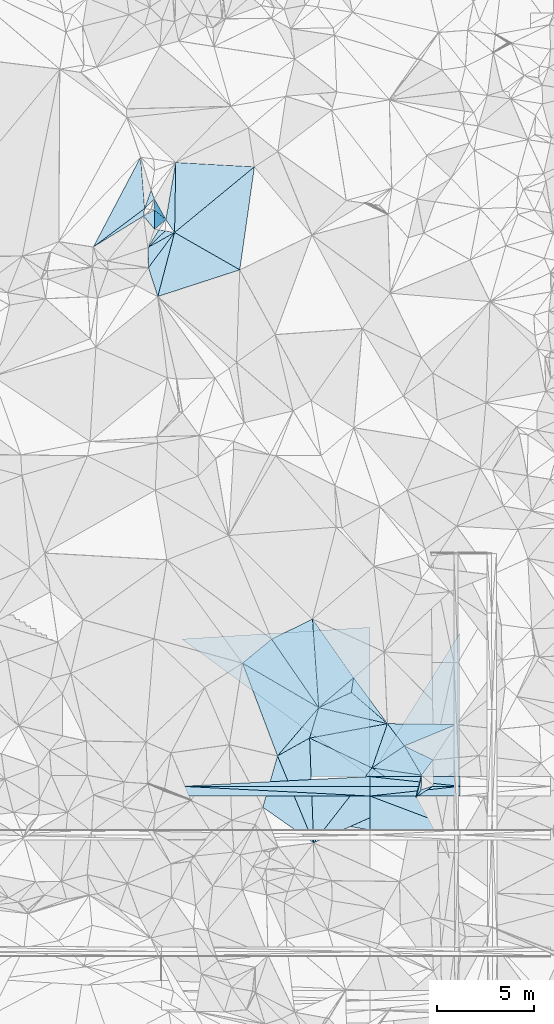
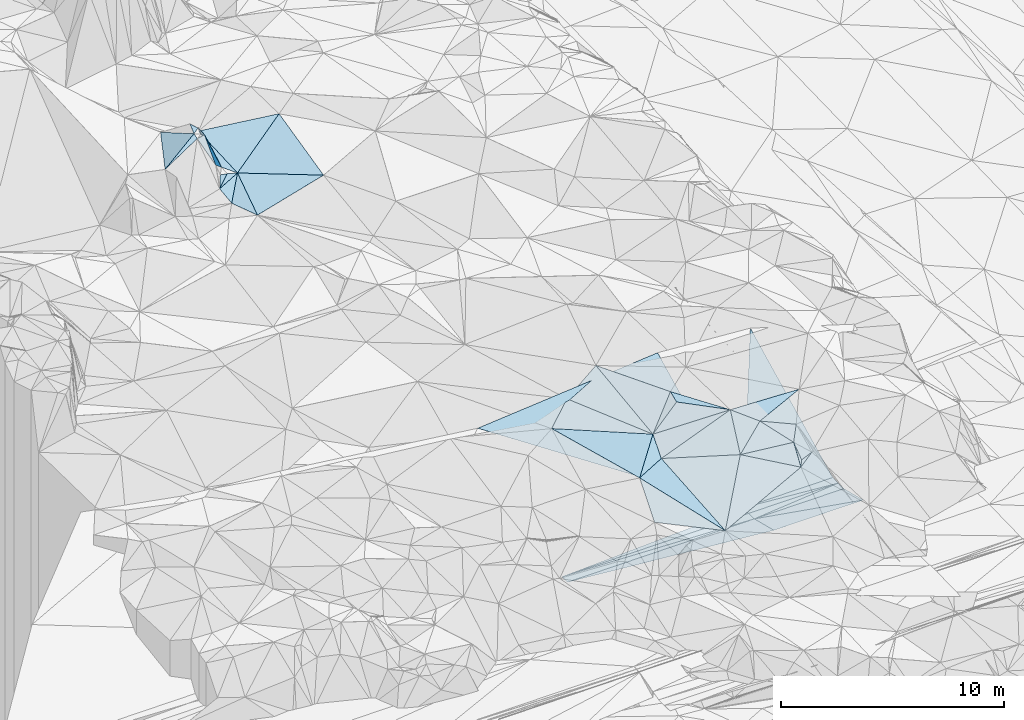
# One storey, part 77 of 275: 47 plates.
"""IFC2X3 building model written with IfcOpenShell, lengths in millimetres."""

from ifc_helpers import new_model, si_unit, frame, origin_with_axes, place, context, subcontext, project, spatial, polyline, outline, extrude, material, type_object, element, save


model = new_model("IFC2X3")

# Units and contexts
model_context = context("Model", 3, precision=1e-05, world=origin_with_axes())
body_context = subcontext(model_context, "Body", "Model", "MODEL_VIEW")
ifc_project = project(units=[si_unit("LENGTHUNIT", "METRE", prefix="MILLI"), si_unit("AREAUNIT", "SQUARE_METRE"), si_unit("VOLUMEUNIT", "CUBIC_METRE"), si_unit("MASSUNIT", "GRAM", prefix="KILO"), si_unit("TIMEUNIT", "SECOND"), si_unit("PLANEANGLEUNIT", "RADIAN"), si_unit("SOLIDANGLEUNIT", "STERADIAN"), si_unit("THERMODYNAMICTEMPERATUREUNIT", "DEGREE_CELSIUS"), si_unit("LUMINOUSINTENSITYUNIT", "LUMEN")], contexts=[model_context])

# Site, building, storey
site_placement = place(None, origin_with_axes())
site = spatial("IfcSite", under=ifc_project, at=site_placement, CompositionType="ELEMENT")
building_placement = place(site_placement, origin_with_axes())
building = spatial("IfcBuilding", under=site, at=building_placement, Name="Undefined", CompositionType="ELEMENT")
storey_placement = place(building_placement, origin_with_axes())
storey = spatial("IfcBuildingStorey", under=building, at=storey_placement, Name="Undefined", CompositionType="ELEMENT", Elevation=0.0)

# Plates
ifc_material = material()
plate_type_1 = type_object("IfcPlateType", PredefinedType="NOTDEFINED")
plate_1_placement = place(storey_placement, frame((-121491.980656783, 95456.9355654821, 53399.5115140249), z_axis=(-0.145244043643726, 0.156607274942495, -0.976922888062873), x_axis=(-0.021187068258557, 0.986674614416757, 0.161320530014474)))
element("IfcPlate", 1, at=plate_1_placement, inside=storey, type_object=plate_type_1, material=ifc_material, Name="00", context=body_context, shape_type="SweptSolid", body=[
    extrude(outline(polyline([(0.0, 0.0), (1053.80261230469, 3.75439412891865e-09), (1769.68615722656, 1396.42785644531), (0.0, 0.0)])), frame((-8.85201319254618e-08, 2.18876761149539e-07, -0.5000001331573), z_axis=(0.0, 0.0, 1.0), x_axis=(1.0, 0.0, 0.0)), (0.0, 0.0, 1.0), 1.0),
])
plate_type_2 = type_object("IfcPlateType", PredefinedType="NOTDEFINED")
plate_2_placement = place(storey_placement, frame((-121514.303984723, 96496.6892032592, 53569.5099623976), z_axis=(-0.137919534677873, 0.143254169517265, -0.980028797980017), x_axis=(0.720392885635616, 0.69356621192615, 1.2509960280384e-10)))
element("IfcPlate", 2, at=plate_2_placement, inside=storey, type_object=plate_type_2, material=ifc_material, Name="00", context=body_context, shape_type="SweptSolid", body=[
    extrude(outline(polyline([(0.0, 0.0), (1224.29577636719, -4.80213202536106e-09), (1516.79040527344, 402.301940917969), (0.0, 0.0)])), frame((-8.85201319254618e-08, 2.18876761149539e-07, -0.5000001331573), z_axis=(0.0, 0.0, 1.0), x_axis=(1.0, 0.0, 0.0)), (0.0, 0.0, 1.0), 1.0),
])
plate_type_3 = type_object("IfcPlateType", PredefinedType="NOTDEFINED")
plate_3_placement = place(storey_placement, frame((-116658.167121345, 75125.2155473122, 51699.5018499605), z_axis=(-0.0256559116857548, 0.0822326815628769, -0.99628287161757), x_axis=(0.861731287211786, -0.503345605832121, -0.063736878883529)))
element("IfcPlate", 3, at=plate_3_placement, inside=storey, type_object=plate_type_3, material=ifc_material, Name="00", context=body_context, shape_type="SweptSolid", body=[
    extrude(outline(polyline([(0.0, 0.0), (4549.9560546875, -7.78527464717627e-10), (3981.13745117188, 3214.13208007813), (0.0, 0.0)])), frame((-8.85201319254618e-08, 2.18876761149539e-07, -0.5000001331573), z_axis=(0.0, 0.0, 1.0), x_axis=(1.0, 0.0, 0.0)), (0.0, 0.0, 1.0), 1.0),
])
plate_type_4 = type_object("IfcPlateType", PredefinedType="NOTDEFINED")
plate_4_placement = place(storey_placement, frame((-108335.575539405, 70866.889105489, 51779.5331533235), z_axis=(0.0161646177763644, 0.357748358320823, -0.933678112226532), x_axis=(0.88752902296513, -0.435175224685755, -0.151376210859778)))
element("IfcPlate", 4, at=plate_4_placement, inside=storey, type_object=plate_type_4, material=ifc_material, Name="00", context=body_context, shape_type="SweptSolid", body=[
    extrude(outline(polyline([(0.0, 0.0), (1651.51440429688, -3.0740920919925e-09), (1521.33093261719, 1015.89971923828), (0.0, 0.0)])), frame((-8.85201319254618e-08, 2.18876761149539e-07, -0.5000001331573), z_axis=(0.0, 0.0, 1.0), x_axis=(1.0, 0.0, 0.0)), (0.0, 0.0, 1.0), 1.0),
])
plate_type_5 = type_object("IfcPlateType", PredefinedType="NOTDEFINED")
for number, where, z_axis, x_axis, name in (
    (5, (-105468.884921601, 68792.9344781819, 48637.3170075506), (0.00703682011736074, -4.02993598015843e-07, -0.99997524127474), (-0.994210620471608, 0.107220772025052, -0.00699629815053093), "00_PR"),
    (6, (-110107.626458422, 69293.20015366, 48604.6740069205), (0.00703682011736074, -4.02993598015843e-07, -0.99997524127474), (0.994210620472886, -0.107220772013634, 0.00699629814400315), "00_PR"),
):
    element("IfcPlate", number, at=place(storey_placement, frame(where, z_axis=z_axis, x_axis=x_axis)), inside=storey, type_object=plate_type_5, material=ifc_material, Name=name, context=body_context, shape_type="SweptSolid", body=[
        extrude(outline(polyline([(0.0, 0.0), (4665.75341796875, -5.16592990607023e-09), (53.5819053649902, 497.120697021484), (0.0, 0.0)])), frame((-8.85201319254618e-08, 2.18876761149539e-07, -0.5000001331573), z_axis=(0.0, 0.0, 1.0), x_axis=(1.0, 0.0, 0.0)), (0.0, 0.0, 1.0), 1.0),
    ])
plate_5_placement = place(storey_placement, frame((-110107.625814173, 69293.2001541532, 48604.674012009), z_axis=(0.00832550512650313, -4.76525014343269e-07, -0.999965342381505), x_axis=(-5.72939716861899e-05, -0.9999999983587, -3.69036567042244e-11)))
element("IfcPlate", 7, at=plate_5_placement, inside=storey, type_object=plate_type_5, material=ifc_material, Name="00_PR", context=body_context, shape_type="SweptSolid", body=[
    extrude(outline(polyline([(0.0, 0.0), (500.0, 8.00355337560177e-10), (499.999786376953, 9668.689453125), (0.0, 0.0)])), frame((-8.85201319254618e-08, 2.18876761149539e-07, -0.5000001331573), z_axis=(0.0, 0.0, 1.0), x_axis=(1.0, 0.0, 0.0)), (0.0, 0.0, 1.0), 1.0),
])
for number, where, z_axis, x_axis, name in (
    (8, (-105468.884921601, 68792.9344781819, 48637.3170075506), (0.00703682011736074, -4.02993598015843e-07, -0.99997524127474), (-5.72939716861899e-05, -0.9999999983587, -3.69036567042244e-11), "00_PR"),
    (9, (-110107.683753915, 68293.2001459784, 48604.6740072747), (0.00703682011736074, -4.02993598015843e-07, -0.99997524127474), (5.72939566107594e-05, 0.999999998358701, 3.92465150362411e-11), "00_PR"),
):
    element("IfcPlate", number, at=place(storey_placement, frame(where, z_axis=z_axis, x_axis=x_axis)), inside=storey, type_object=plate_type_5, material=ifc_material, Name=name, context=body_context, shape_type="SweptSolid", body=[
        extrude(outline(polyline([(0.0, 0.0), (500.0, 8.00355337560177e-10), (500.000091552734, 4638.88525390625), (0.0, 0.0)])), frame((-8.85201319254618e-08, 2.18876761149539e-07, -0.5000001331573), z_axis=(0.0, 0.0, 1.0), x_axis=(1.0, 0.0, 0.0)), (0.0, 0.0, 1.0), 1.0),
    ])
for number, where, z_axis, x_axis, name in (
    (10, (-119776.008774443, 68793.7543278347, 48524.17701052), (0.00832550512650313, -4.76525014343269e-07, -0.999965342381505), (0.998627967402267, -0.0517015939711349, 0.00831431914595258), "00_PR"),
    (11, (-110107.683106759, 68293.200145298, 48604.6740122975), (0.00832550512650313, -4.76525014343269e-07, -0.999965342381505), (-0.998627967401277, 0.0517015939893386, -0.00831431915169653), "00_PR"),
):
    element("IfcPlate", number, at=place(storey_placement, frame(where, z_axis=z_axis, x_axis=x_axis)), inside=storey, type_object=plate_type_5, material=ifc_material, Name=name, context=body_context, shape_type="SweptSolid", body=[
        extrude(outline(polyline([(0.0, 0.0), (9681.609375, -1.20489858090878e-08), (25.8221664428711, 499.332763671875), (0.0, 0.0)])), frame((-8.85201319254618e-08, 2.18876761149539e-07, -0.5000001331573), z_axis=(0.0, 0.0, 1.0), x_axis=(1.0, 0.0, 0.0)), (0.0, 0.0, 1.0), 1.0),
    ])
plate_type_6 = type_object("IfcPlateType", PredefinedType="NOTDEFINED")
plate_6_placement = place(storey_placement, frame((-113058.252267618, 77394.6399255898, 52519.5254217645), z_axis=(0.197861321106746, 0.244990522690057, -0.949120930862841), x_axis=(0.570396779252502, -0.816225689000043, -0.0917776597804555)))
element("IfcPlate", 12, at=plate_6_placement, inside=storey, type_object=plate_type_6, material=ifc_material, Name="00", context=body_context, shape_type="SweptSolid", body=[
    extrude(outline(polyline([(0.0, 0.0), (3704.60522460938, -2.03726813197136e-08), (4006.60766601563, 2464.08081054688), (0.0, 0.0)])), frame((-8.85201319254618e-08, 2.18876761149539e-07, -0.5000001331573), z_axis=(0.0, 0.0, 1.0), x_axis=(1.0, 0.0, 0.0)), (0.0, 0.0, 1.0), 1.0),
])
plate_type_7 = type_object("IfcPlateType", PredefinedType="NOTDEFINED")
plate_7_placement = place(storey_placement, frame((-107453.118329928, 69365.4981168583, 51219.5382379114), z_axis=(0.0589039544589741, 0.379068719327765, -0.923491867953532), x_axis=(-0.989526104038658, 0.144301784820489, -0.00388385423208294)))
element("IfcPlate", 13, at=plate_7_placement, inside=storey, type_object=plate_type_7, material=ifc_material, Name="00", context=body_context, shape_type="SweptSolid", body=[
    extrude(outline(polyline([(0.0, 0.0), (2574.76220703125, 2.43016984313726e-09), (1087.67333984375, 1470.87280273438), (0.0, 0.0)])), frame((-8.85201319254618e-08, 2.18876761149539e-07, -0.5000001331573), z_axis=(0.0, 0.0, 1.0), x_axis=(1.0, 0.0, 0.0)), (0.0, 0.0, 1.0), 1.0),
])
plate_type_8 = type_object("IfcPlateType", PredefinedType="NOTDEFINED")
plate_8_placement = place(storey_placement, frame((-114856.193535018, 70356.6749841936, 51259.507951789), z_axis=(-0.116281114862907, 0.134398896140523, -0.984081114056381), x_axis=(0.873875615125201, 0.484735152316241, -0.0370572718707482)))
element("IfcPlate", 14, at=plate_8_placement, inside=storey, type_object=plate_type_8, material=ifc_material, Name="00", context=body_context, shape_type="SweptSolid", body=[
    extrude(outline(polyline([(0.0, 0.0), (1888.96801757813, 6.54836185276508e-10), (-514.302001953125, 4884.88427734375), (0.0, 0.0)])), frame((-8.85201319254618e-08, 2.18876761149539e-07, -0.5000001331573), z_axis=(0.0, 0.0, 1.0), x_axis=(1.0, 0.0, 0.0)), (0.0, 0.0, 1.0), 1.0),
])
plate_type_9 = type_object("IfcPlateType", PredefinedType="NOTDEFINED")
plate_9_placement = place(storey_placement, frame((-112737.268732479, 72835.0948948373, 51409.5169961411), z_axis=(0.0922023741555557, 0.241653469669306, -0.965972216369014), x_axis=(-0.560003411586896, 0.814730872466991, 0.150365502892828)))
element("IfcPlate", 15, at=plate_9_placement, inside=storey, type_object=plate_type_9, material=ifc_material, Name="00", context=body_context, shape_type="SweptSolid", body=[
    extrude(outline(polyline([(0.0, 0.0), (4322.7998046875, 3.24580469168723e-08), (4061.48779296875, 2372.53369140625), (0.0, 0.0)])), frame((-8.85201319254618e-08, 2.18876761149539e-07, -0.5000001331573), z_axis=(0.0, 0.0, 1.0), x_axis=(1.0, 0.0, 0.0)), (0.0, 0.0, 1.0), 1.0),
])
plate_type_10 = type_object("IfcPlateType", PredefinedType="NOTDEFINED")
plate_10_placement = place(storey_placement, frame((-121011.464245367, 93974.5100086701, 53479.502445469), z_axis=(0.0967190391103134, -0.0223575900648491, -0.995060583904352), x_axis=(-0.307888860082838, 0.950039774583614, -0.0512725710883228)))
element("IfcPlate", 16, at=plate_10_placement, inside=storey, type_object=plate_type_10, material=ifc_material, Name="00", context=body_context, shape_type="SweptSolid", body=[
    extrude(outline(polyline([(0.0, 0.0), (1560.28845214844, 9.24046617001295e-09), (2859.34301757813, 1842.35095214844), (0.0, 0.0)])), frame((-8.85201319254618e-08, 2.18876761149539e-07, -0.5000001331573), z_axis=(0.0, 0.0, 1.0), x_axis=(1.0, 0.0, 0.0)), (0.0, 0.0, 1.0), 1.0),
])
plate_type_11 = type_object("IfcPlateType", PredefinedType="NOTDEFINED")
plate_11_placement = place(storey_placement, frame((-121688.040251305, 98497.2145120116, 55429.5025942348), z_axis=(-0.0940857772697721, 0.0399869239065555, -0.994760731247487), x_axis=(-0.149852085832661, -0.988378057479931, -0.0255571489763316)))
element("IfcPlate", 17, at=plate_11_placement, inside=storey, type_object=plate_type_11, material=ifc_material, Name="00", context=body_context, shape_type="SweptSolid", body=[
    extrude(outline(polyline([(0.0, 0.0), (391.279937744141, -1.80443748831749e-09), (2342.568359375, 2322.27783203125), (0.0, 0.0)])), frame((-8.85201319254618e-08, 2.18876761149539e-07, -0.5000001331573), z_axis=(0.0, 0.0, 1.0), x_axis=(1.0, 0.0, 0.0)), (0.0, 0.0, 1.0), 1.0),
])
plate_type_12 = type_object("IfcPlateType", PredefinedType="NOTDEFINED")
for number, where, z_axis, x_axis, name in (
    (18, (-105469.013941347, 66542.8131981337, 49074.831934969), (0.00681283794778126, -0.242530362302773, -0.970119893930839), (-0.999975239635043, 5.72709690146696e-05, -0.00703682008264182), "00_PR"),
    (19, (-110107.683861125, 68293.0788822064, 48604.688934529), (0.00681283794778126, -0.242530362302773, -0.970119893930839), (0.99997523963564, -5.72709999785377e-05, 0.00703681999743575), "00_PR"),
):
    element("IfcPlate", number, at=place(storey_placement, frame(where, z_axis=z_axis, x_axis=x_axis)), inside=storey, type_object=plate_type_12, material=ifc_material, Name=name, context=body_context, shape_type="SweptSolid", body=[
        extrude(outline(polyline([(0.0, 0.0), (4638.88525390625, 2.71393219009042e-09), (4641.96337890625, 1803.85607910156), (0.0, 0.0)])), frame((-8.85201319254618e-08, 2.18876761149539e-07, -0.5000001331573), z_axis=(0.0, 0.0, 1.0), x_axis=(1.0, 0.0, 0.0)), (0.0, 0.0, 1.0), 1.0),
    ])
plate_type_13 = type_object("IfcPlateType", PredefinedType="NOTDEFINED")
plate_12_placement = place(storey_placement, frame((-119776.037549467, 68293.6330597167, 48524.1919376552), z_axis=(0.00806306952558709, -0.242528174049018, -0.970110855367713), x_axis=(0.999965340787191, -5.73519775278889e-05, 0.0083254990906575)))
element("IfcPlate", 20, at=plate_12_placement, inside=storey, type_object=plate_type_13, material=ifc_material, Name="00_PR", context=body_context, shape_type="SweptSolid", body=[
    extrude(outline(polyline([(0.0, 0.0), (9668.689453125, -4.80504240840673e-08), (9672.33203125, 1803.85510253906), (0.0, 0.0)])), frame((-8.85201319254618e-08, 2.18876761149539e-07, -0.5000001331573), z_axis=(0.0, 0.0, 1.0), x_axis=(1.0, 0.0, 0.0)), (0.0, 0.0, 1.0), 1.0),
])
plate_type_14 = type_object("IfcPlateType", PredefinedType="NOTDEFINED")
plate_13_placement = place(storey_placement, frame((-105468.432899384, 76686.6310738578, 52334.1057906419), z_axis=(0.0063195673830604, 0.447204327533506, -0.894409499336515), x_axis=(-5.11789581372139e-05, -0.894427148801689, -0.447213676967951)))
element("IfcPlate", 21, at=plate_13_placement, inside=storey, type_object=plate_type_14, material=ifc_material, Name="00_PR", context=body_context, shape_type="SweptSolid", body=[
    extrude(outline(polyline([(0.0, 0.0), (8266.154296875, 5.1964889280498e-08), (8280.7529296875, 4638.8623046875), (0.0, 0.0)])), frame((-8.85201319254618e-08, 2.18876761149539e-07, -0.5000001331573), z_axis=(0.0, 0.0, 1.0), x_axis=(1.0, 0.0, 0.0)), (0.0, 0.0, 1.0), 1.0),
])
plate_type_15 = type_object("IfcPlateType", PredefinedType="NOTDEFINED")
plate_14_placement = place(storey_placement, frame((-110107.626236969, 69293.4237529414, 48604.7267930774), z_axis=(0.00747221277555471, 0.447200796920443, -0.894402377719311), x_axis=(-0.775638983085912, 0.567110016995723, 0.277074712921559)))
element("IfcPlate", 22, at=plate_14_placement, inside=storey, type_object=plate_type_15, material=ifc_material, Name="00_PR", context=body_context, shape_type="SweptSolid", body=[
    extrude(outline(polyline([(0.0, 0.0), (12464.4970703125, -7.41783878766e-08), (5415.0244140625, 6655.5654296875), (0.0, 0.0)])), frame((-8.85201319254618e-08, 2.18876761149539e-07, -0.5000001331573), z_axis=(0.0, 0.0, 1.0), x_axis=(1.0, 0.0, 0.0)), (0.0, 0.0, 1.0), 1.0),
])
plate_type_16 = type_object("IfcPlateType", PredefinedType="NOTDEFINED")
plate_15_placement = place(storey_placement, frame((-107730.488703782, 68237.0074074578, 50639.5529672701), z_axis=(0.0680767358260334, 0.442761970947046, -0.894051114379016), x_axis=(-0.816618366707683, 0.539539481148274, 0.205016076047534)))
element("IfcPlate", 23, at=plate_15_placement, inside=storey, type_object=plate_type_16, material=ifc_material, Name="00", context=body_context, shape_type="SweptSolid", body=[
    extrude(outline(polyline([(0.0, 0.0), (2780.26977539063, -5.39148459210992e-09), (501.282287597656, 1198.17199707031), (0.0, 0.0)])), frame((-8.85201319254618e-08, 2.18876761149539e-07, -0.5000001331573), z_axis=(0.0, 0.0, 1.0), x_axis=(1.0, 0.0, 0.0)), (0.0, 0.0, 1.0), 1.0),
])
plate_type_17 = type_object("IfcPlateType", PredefinedType="NOTDEFINED")
plate_16_placement = place(storey_placement, frame((-107453.393253021, 69365.5538901862, 51219.6400577027), z_axis=(-0.49097096958293, 0.490648015244369, -0.719869454945519), x_axis=(-0.0196315247335214, -0.832340581005681, -0.553916745050881)))
element("IfcPlate", 24, at=plate_16_placement, inside=storey, type_object=plate_type_17, material=ifc_material, Name="00", context=body_context, shape_type="SweptSolid", body=[
    extrude(outline(polyline([(0.0, 0.0), (902.662719726563, 2.5902409106493e-09), (1266.03210449219, 289.935668945313), (0.0, 0.0)])), frame((-8.85201319254618e-08, 2.18876761149539e-07, -0.5000001331573), z_axis=(0.0, 0.0, 1.0), x_axis=(1.0, 0.0, 0.0)), (0.0, 0.0, 1.0), 1.0),
])
plate_type_18 = type_object("IfcPlateType", PredefinedType="NOTDEFINED")
plate_17_placement = place(storey_placement, frame((-106820.606895874, 68825.0042425534, 50789.5082972044), z_axis=(0.0491927436658262, 0.174703746110266, -0.983391414984729), x_axis=(-0.831896768182121, -0.537717189407043, -0.137142230200373)))
element("IfcPlate", 25, at=plate_17_placement, inside=storey, type_object=plate_type_18, material=ifc_material, Name="00", context=body_context, shape_type="SweptSolid", body=[
    extrude(outline(polyline([(0.0, 0.0), (1093.75500488281, -2.51748133450747e-09), (663.951232910156, 177.112213134766), (0.0, 0.0)])), frame((-8.85201319254618e-08, 2.18876761149539e-07, -0.5000001331573), z_axis=(0.0, 0.0, 1.0), x_axis=(1.0, 0.0, 0.0)), (0.0, 0.0, 1.0), 1.0),
])
plate_type_19 = type_object("IfcPlateType", PredefinedType="NOTDEFINED")
plate_18_placement = place(storey_placement, frame((-121174.547134293, 97434.4430739002, 54169.7108411786), z_axis=(-0.527316893555232, 0.622526021330921, -0.578271775670535), x_axis=(-0.373554710490937, 0.441424030220653, 0.815844166378475)))
element("IfcPlate", 26, at=plate_18_placement, inside=storey, type_object=plate_type_19, material=ifc_material, Name="00", context=body_context, shape_type="SweptSolid", body=[
    extrude(outline(polyline([(0.0, 0.0), (1532.15539550781, -6.33008312433958e-09), (1323.95190429688, 621.330261230469), (0.0, 0.0)])), frame((-8.85201319254618e-08, 2.18876761149539e-07, -0.5000001331573), z_axis=(0.0, 0.0, 1.0), x_axis=(1.0, 0.0, 0.0)), (0.0, 0.0, 1.0), 1.0),
])
plate_type_20 = type_object("IfcPlateType", PredefinedType="NOTDEFINED")
plate_19_placement = place(storey_placement, frame((-120148.157190914, 97264.5980100406, 53489.5035081095), z_axis=(-0.115588457791261, 0.0267032868728589, -0.992938186845296), x_axis=(-0.555624905957884, 0.826877397549843, 0.0869179688010019)))
element("IfcPlate", 27, at=plate_19_placement, inside=storey, type_object=plate_type_20, material=ifc_material, Name="00", context=body_context, shape_type="SweptSolid", body=[
    extrude(outline(polyline([(0.0, 0.0), (805.357055664063, 2.16095941141248e-09), (2952.97583007813, 2064.22705078125), (0.0, 0.0)])), frame((-8.85201319254618e-08, 2.18876761149539e-07, -0.5000001331573), z_axis=(0.0, 0.0, 1.0), x_axis=(1.0, 0.0, 0.0)), (0.0, 0.0, 1.0), 1.0),
])
plate_type_21 = type_object("IfcPlateType", PredefinedType="NOTDEFINED")
plate_20_placement = place(storey_placement, frame((-110945.069354077, 74370.7377192365, 52179.5364687555), z_axis=(0.373857355079543, 0.0285538774434559, -0.927046576033736), x_axis=(-0.152249070697096, -0.984078069635626, -0.0917091780253864)))
element("IfcPlate", 28, at=plate_20_placement, inside=storey, type_object=plate_type_21, material=ifc_material, Name="00", context=body_context, shape_type="SweptSolid", body=[
    extrude(outline(polyline([(0.0, 0.0), (763.282409667969, -2.83762346953154e-09), (1854.75256347656, 1650.08874511719), (0.0, 0.0)])), frame((-8.85201319254618e-08, 2.18876761149539e-07, -0.5000001331573), z_axis=(0.0, 0.0, 1.0), x_axis=(1.0, 0.0, 0.0)), (0.0, 0.0, 1.0), 1.0),
])
plate_type_22 = type_object("IfcPlateType", PredefinedType="NOTDEFINED")
plate_21_placement = place(storey_placement, frame((-109203.473277562, 72013.7714502133, 52009.5021223309), z_axis=(0.0234729329810426, 0.0891644609744923, -0.995740287583261), x_axis=(-0.755945143999181, 0.653369387696135, 0.0406863918974805)))
element("IfcPlate", 29, at=plate_21_placement, inside=storey, type_object=plate_type_22, material=ifc_material, Name="00", context=body_context, shape_type="SweptSolid", body=[
    extrude(outline(polyline([(0.0, 0.0), (2457.82421875, -1.45446392707527e-08), (2863.58959960938, 646.493957519531), (0.0, 0.0)])), frame((-8.85201319254618e-08, 2.18876761149539e-07, -0.5000001331573), z_axis=(0.0, 0.0, 1.0), x_axis=(1.0, 0.0, 0.0)), (0.0, 0.0, 1.0), 1.0),
])
plate_type_23 = type_object("IfcPlateType", PredefinedType="NOTDEFINED")
plate_22_placement = place(storey_placement, frame((-115158.070027408, 76357.00153501, 52059.5127633394), z_axis=(0.0550936653417499, 0.217712764895167, -0.974456689669127), x_axis=(0.560003411611734, -0.814730872423076, -0.150365503038269)))
element("IfcPlate", 30, at=plate_22_placement, inside=storey, type_object=plate_type_23, material=ifc_material, Name="00", context=body_context, shape_type="SweptSolid", body=[
    extrude(outline(polyline([(0.0, 0.0), (4322.7998046875, 3.24580469168723e-08), (217.613586425781, 1962.02551269531), (0.0, 0.0)])), frame((-8.85201319254618e-08, 2.18876761149539e-07, -0.5000001331573), z_axis=(0.0, 0.0, 1.0), x_axis=(1.0, 0.0, 0.0)), (0.0, 0.0, 1.0), 1.0),
])
plate_type_24 = type_object("IfcPlateType", PredefinedType="NOTDEFINED")
plate_23_placement = place(storey_placement, frame((-109203.414121995, 72013.8686538172, 52009.5257871362), z_axis=(0.141790984729408, 0.283571175294942, -0.948410620560161), x_axis=(-0.313752864656696, -0.895817763869704, -0.31475335400151)))
element("IfcPlate", 31, at=plate_23_placement, inside=storey, type_object=plate_type_24, material=ifc_material, Name="00", context=body_context, shape_type="SweptSolid", body=[
    extrude(outline(polyline([(0.0, 0.0), (2541.67260742188, -3.20142135024071e-10), (2177.93579101563, 3534.712890625), (0.0, 0.0)])), frame((-8.85201319254618e-08, 2.18876761149539e-07, -0.5000001331573), z_axis=(0.0, 0.0, 1.0), x_axis=(1.0, 0.0, 0.0)), (0.0, 0.0, 1.0), 1.0),
])
plate_type_25 = type_object("IfcPlateType", PredefinedType="NOTDEFINED")
plate_24_placement = place(storey_placement, frame((-112999.756514647, 65885.5580706147, 50429.5177629486), z_axis=(-0.0746690329107958, 0.253463317820296, -0.964458854510494), x_axis=(0.606655940640961, 0.779146551872674, 0.157794868072296)))
element("IfcPlate", 32, at=plate_24_placement, inside=storey, type_object=plate_type_25, material=ifc_material, Name="00", context=body_context, shape_type="SweptSolid", body=[
    extrude(outline(polyline([(0.0, 0.0), (4943.12646484375, -3.48954927176237e-08), (5061.7763671875, 2777.73681640625), (0.0, 0.0)])), frame((-8.85201319254618e-08, 2.18876761149539e-07, -0.5000001331573), z_axis=(0.0, 0.0, 1.0), x_axis=(1.0, 0.0, 0.0)), (0.0, 0.0, 1.0), 1.0),
])
plate_type_26 = type_object("IfcPlateType", PredefinedType="NOTDEFINED")
plate_25_placement = place(storey_placement, frame((-112999.700772426, 65885.5299163333, 50429.510151645), z_axis=(0.0368215209775154, 0.197149863330098, -0.979681635523411), x_axis=(-0.816219222141147, 0.571552977853969, 0.0843408259003996)))
element("IfcPlate", 33, at=plate_25_placement, inside=storey, type_object=plate_type_26, material=ifc_material, Name="00", context=body_context, shape_type="SweptSolid", body=[
    extrude(outline(polyline([(0.0, 0.0), (3201.29663085938, 1.99106580112129e-08), (4140.759765625, 2642.10327148438), (0.0, 0.0)])), frame((-8.85201319254618e-08, 2.18876761149539e-07, -0.5000001331573), z_axis=(0.0, 0.0, 1.0), x_axis=(1.0, 0.0, 0.0)), (0.0, 0.0, 1.0), 1.0),
])
plate_type_27 = type_object("IfcPlateType", PredefinedType="NOTDEFINED")
plate_26_placement = place(storey_placement, frame((-113205.319668225, 71272.2981390107, 51189.510376681), z_axis=(0.185389055289099, 0.0823221540551721, -0.979210886954762), x_axis=(0.284369986805267, 0.949353093091194, 0.133650346960098)))
element("IfcPlate", 34, at=plate_26_placement, inside=storey, type_object=plate_type_27, material=ifc_material, Name="00", context=body_context, shape_type="SweptSolid", body=[
    extrude(outline(polyline([(0.0, 0.0), (1646.08630371094, -6.46105036139488e-09), (1951.5380859375, 3664.57348632813), (0.0, 0.0)])), frame((-8.85201319254618e-08, 2.18876761149539e-07, -0.5000001331573), z_axis=(0.0, 0.0, 1.0), x_axis=(1.0, 0.0, 0.0)), (0.0, 0.0, 1.0), 1.0),
])
plate_type_28 = type_object("IfcPlateType", PredefinedType="NOTDEFINED")
plate_27_placement = place(storey_placement, frame((-121352.22051681, 99443.8267411701, 55279.519486349), z_axis=(-0.270855851738838, -0.0561599217566236, -0.960980317575297), x_axis=(0.344950883298135, -0.937661297127824, -0.042428527907569)))
element("IfcPlate", 35, at=plate_27_placement, inside=storey, type_object=plate_type_28, material=ifc_material, Name="00", context=body_context, shape_type="SweptSolid", body=[
    extrude(outline(polyline([(0.0, 0.0), (471.380950927734, -1.33877620100975e-09), (765.41064453125, 667.567626953125), (0.0, 0.0)])), frame((-8.85201319254618e-08, 2.18876761149539e-07, -0.5000001331573), z_axis=(0.0, 0.0, 1.0), x_axis=(1.0, 0.0, 0.0)), (0.0, 0.0, 1.0), 1.0),
])
plate_type_29 = type_object("IfcPlateType", PredefinedType="NOTDEFINED")
plate_28_placement = place(storey_placement, frame((-109203.42048672, 72013.8709483145, 52009.5255653937), z_axis=(0.129298277048337, 0.28809490665086, -0.948832588138795), x_axis=(0.595824236396827, -0.787440040560561, -0.157897630900909)))
element("IfcPlate", 36, at=plate_28_placement, inside=storey, type_object=plate_type_29, material=ifc_material, Name="00", context=body_context, shape_type="SweptSolid", body=[
    extrude(outline(polyline([(0.0, 0.0), (1456.64001464844, -2.71393219009042e-09), (1444.07678222656, 2091.58837890625), (0.0, 0.0)])), frame((-8.85201319254618e-08, 2.18876761149539e-07, -0.5000001331573), z_axis=(0.0, 0.0, 1.0), x_axis=(1.0, 0.0, 0.0)), (0.0, 0.0, 1.0), 1.0),
])
plate_type_30 = type_object("IfcPlateType", PredefinedType="NOTDEFINED")
plate_29_placement = place(storey_placement, frame((-121514.261110115, 96496.6446700266, 53569.5013934144), z_axis=(-0.0521703322920128, 0.0541882458273035, -0.997166932084443), x_axis=(0.523263432916492, 0.851960899257435, 0.0189210440755991)))
element("IfcPlate", 37, at=plate_29_placement, inside=storey, type_object=plate_type_30, material=ifc_material, Name="00", context=body_context, shape_type="SweptSolid", body=[
    extrude(outline(polyline([(0.0, 0.0), (1057.02416992188, 4.88944351673126e-09), (1184.93041992188, 307.961029052734), (0.0, 0.0)])), frame((-8.85201319254618e-08, 2.18876761149539e-07, -0.5000001331573), z_axis=(0.0, 0.0, 1.0), x_axis=(1.0, 0.0, 0.0)), (0.0, 0.0, 1.0), 1.0),
])
plate_type_31 = type_object("IfcPlateType", PredefinedType="NOTDEFINED")
plate_30_placement = place(storey_placement, frame((-124324.528624227, 96522.2196505764, 55599.5744947393), z_axis=(0.278605525286209, -0.445248428536722, -0.850959927473424), x_axis=(0.444890478857797, 0.845075830067828, -0.29651189395512)))
element("IfcPlate", 38, at=plate_30_placement, inside=storey, type_object=plate_type_31, material=ifc_material, Name="00", context=body_context, shape_type="SweptSolid", body=[
    extrude(outline(polyline([(0.0, 0.0), (5463.5244140625, 2.20898073166609e-08), (2892.25390625, 1586.0224609375), (0.0, 0.0)])), frame((-8.85201319254618e-08, 2.18876761149539e-07, -0.5000001331573), z_axis=(0.0, 0.0, 1.0), x_axis=(1.0, 0.0, 0.0)), (0.0, 0.0, 1.0), 1.0),
])
plate_type_32 = type_object("IfcPlateType", PredefinedType="NOTDEFINED")
plate_31_placement = place(storey_placement, frame((-113205.375235835, 71272.3280247537, 51189.5064493971), z_axis=(0.0742446286696549, 0.14209496490597, -0.987064717261273), x_axis=(0.901809388029687, -0.43209738283686, 0.00562844623838089)))
element("IfcPlate", 39, at=plate_31_placement, inside=storey, type_object=plate_type_32, material=ifc_material, Name="00", context=body_context, shape_type="SweptSolid", body=[
    extrude(outline(polyline([(0.0, 0.0), (3553.37866210938, 3.15776560455561e-09), (2508.8515625, 4831.50732421875), (0.0, 0.0)])), frame((-8.85201319254618e-08, 2.18876761149539e-07, -0.5000001331573), z_axis=(0.0, 0.0, 1.0), x_axis=(1.0, 0.0, 0.0)), (0.0, 0.0, 1.0), 1.0),
])
plate_type_33 = type_object("IfcPlateType", PredefinedType="NOTDEFINED")
plate_32_placement = place(storey_placement, frame((-112737.199251901, 72835.1363458683, 51409.5413887224), z_axis=(0.231152469128801, 0.324556988518438, -0.917186620715491), x_axis=(0.847069522249934, 0.39659148138601, 0.353819758305437)))
element("IfcPlate", 40, at=plate_32_placement, inside=storey, type_object=plate_type_33, material=ifc_material, Name="00", context=body_context, shape_type="SweptSolid", body=[
    extrude(outline(polyline([(0.0, 0.0), (1978.40844726563, -1.29512045532465e-09), (2879.99169921875, 2286.49243164063), (0.0, 0.0)])), frame((-8.85201319254618e-08, 2.18876761149539e-07, -0.5000001331573), z_axis=(0.0, 0.0, 1.0), x_axis=(1.0, 0.0, 0.0)), (0.0, 0.0, 1.0), 1.0),
])
plate_type_34 = type_object("IfcPlateType", PredefinedType="NOTDEFINED")
plate_33_placement = place(storey_placement, frame((-108335.595057553, 70866.8002045769, 51779.508274807), z_axis=(-0.0228466881542998, 0.179908016083594, -0.98341808738158), x_axis=(-0.595824236111615, 0.787440040804806, 0.157897630759096)))
element("IfcPlate", 41, at=plate_33_placement, inside=storey, type_object=plate_type_34, material=ifc_material, Name="00", context=body_context, shape_type="SweptSolid", body=[
    extrude(outline(polyline([(0.0, 0.0), (1456.64001464844, -2.71393219009042e-09), (-699.8984375, 2808.33447265625), (0.0, 0.0)])), frame((-8.85201319254618e-08, 2.18876761149539e-07, -0.5000001331573), z_axis=(0.0, 0.0, 1.0), x_axis=(1.0, 0.0, 0.0)), (0.0, 0.0, 1.0), 1.0),
])
plate_type_35 = type_object("IfcPlateType", PredefinedType="NOTDEFINED")
plate_34_placement = place(storey_placement, frame((-116796.163819103, 95346.0961775201, 53359.5005743476), z_axis=(-0.0468028721028284, -0.014092757095783, -0.998804728343016), x_axis=(-0.8674085692659, 0.49645811490567, 0.0336409587912103)))
element("IfcPlate", 42, at=plate_34_placement, inside=storey, type_object=plate_type_35, material=ifc_material, Name="00", context=body_context, shape_type="SweptSolid", body=[
    extrude(outline(polyline([(0.0, 0.0), (3864.3369140625, -1.52067514136434e-08), (1973.01635742188, 4973.91259765625), (0.0, 0.0)])), frame((-8.85201319254618e-08, 2.18876761149539e-07, -0.5000001331573), z_axis=(0.0, 0.0, 1.0), x_axis=(1.0, 0.0, 0.0)), (0.0, 0.0, 1.0), 1.0),
])
plate_type_36 = type_object("IfcPlateType", PredefinedType="NOTDEFINED")
plate_35_placement = place(storey_placement, frame((-120148.115488392, 97264.590401479, 53489.5002690913), z_axis=(-0.032187440087715, 0.0114846477721219, -0.999415865176329), x_axis=(0.867408569261931, -0.496458114912444, -0.0336409587936031)))
element("IfcPlate", 43, at=plate_35_placement, inside=storey, type_object=plate_type_36, material=ifc_material, Name="00", context=body_context, shape_type="SweptSolid", body=[
    extrude(outline(polyline([(0.0, 0.0), (3864.3369140625, -1.52067514136434e-08), (884.783081054688, 3284.39624023438), (0.0, 0.0)])), frame((-8.85201319254618e-08, 2.18876761149539e-07, -0.5000001331573), z_axis=(0.0, 0.0, 1.0), x_axis=(1.0, 0.0, 0.0)), (0.0, 0.0, 1.0), 1.0),
])
plate_type_37 = type_object("IfcPlateType", PredefinedType="NOTDEFINED")
plate_36_placement = place(storey_placement, frame((-120596.046405834, 97930.5233227658, 53559.831100969), z_axis=(-0.941127522045462, 0.0142231192156048, -0.337752409507834), x_axis=(-0.322330275138941, 0.263390184879413, 0.909246283598698)))
element("IfcPlate", 44, at=plate_36_placement, inside=storey, type_object=plate_type_37, material=ifc_material, Name="00", context=body_context, shape_type="SweptSolid", body=[
    extrude(outline(polyline([(0.0, 0.0), (1858.68237304688, 8.87666828930378e-10), (2019.33374023438, 559.27734375), (0.0, 0.0)])), frame((-8.85201319254618e-08, 2.18876761149539e-07, -0.5000001331573), z_axis=(0.0, 0.0, 1.0), x_axis=(1.0, 0.0, 0.0)), (0.0, 0.0, 1.0), 1.0),
])
plate_type_38 = type_object("IfcPlateType", PredefinedType="NOTDEFINED")
plate_37_placement = place(storey_placement, frame((-121195.086959815, 98420.2911183919, 55249.7949954635), z_axis=(-0.803065770903632, 0.432453955860638, -0.40996212466939), x_axis=(0.322330275135004, -0.263390184878691, -0.909246283600302)))
element("IfcPlate", 45, at=plate_37_placement, inside=storey, type_object=plate_type_38, material=ifc_material, Name="00", context=body_context, shape_type="SweptSolid", body=[
    extrude(outline(polyline([(0.0, 0.0), (1858.68237304688, 8.87666828930378e-10), (1248.24987792969, 762.084106445313), (0.0, 0.0)])), frame((-8.85201319254618e-08, 2.18876761149539e-07, -0.5000001331573), z_axis=(0.0, 0.0, 1.0), x_axis=(1.0, 0.0, 0.0)), (0.0, 0.0, 1.0), 1.0),
])
plate_type_39 = type_object("IfcPlateType", PredefinedType="NOTDEFINED")
plate_38_placement = place(storey_placement, frame((-120089.28605965, 100865.92200296, 53579.5017441132), z_axis=(-0.0798333413493299, 0.0262070763429517, -0.996463660530858), x_axis=(0.995186556349221, -0.0549030148062065, -0.0811749778378105)))
element("IfcPlate", 46, at=plate_38_placement, inside=storey, type_object=plate_type_39, material=ifc_material, Name="00", context=body_context, shape_type="SweptSolid", body=[
    extrude(outline(polyline([(0.0, 0.0), (4065.29223632813, -1.25146470963955e-09), (146.459335327148, 3599.95141601563), (0.0, 0.0)])), frame((-8.85201319254618e-08, 2.18876761149539e-07, -0.5000001331573), z_axis=(0.0, 0.0, 1.0), x_axis=(1.0, 0.0, 0.0)), (0.0, 0.0, 1.0), 1.0),
])
plate_type_40 = type_object("IfcPlateType", PredefinedType="NOTDEFINED")
plate_39_placement = place(storey_placement, frame((-112737.385292561, 72835.0636988806, 51409.5131316366), z_axis=(-0.140704964660996, 0.179224009829577, -0.973694442430661), x_axis=(-0.284369986519152, -0.949353093298737, -0.133650346094642)))
element("IfcPlate", 47, at=plate_39_placement, inside=storey, type_object=plate_type_40, material=ifc_material, Name="00", context=body_context, shape_type="SweptSolid", body=[
    extrude(outline(polyline([(0.0, 0.0), (1646.08630371094, -6.46105036139488e-09), (2975.42114257813, 1342.03894042969), (0.0, 0.0)])), frame((-8.85201319254618e-08, 2.18876761149539e-07, -0.5000001331573), z_axis=(0.0, 0.0, 1.0), x_axis=(1.0, 0.0, 0.0)), (0.0, 0.0, 1.0), 1.0),
])

save(model, "model.ifc")
